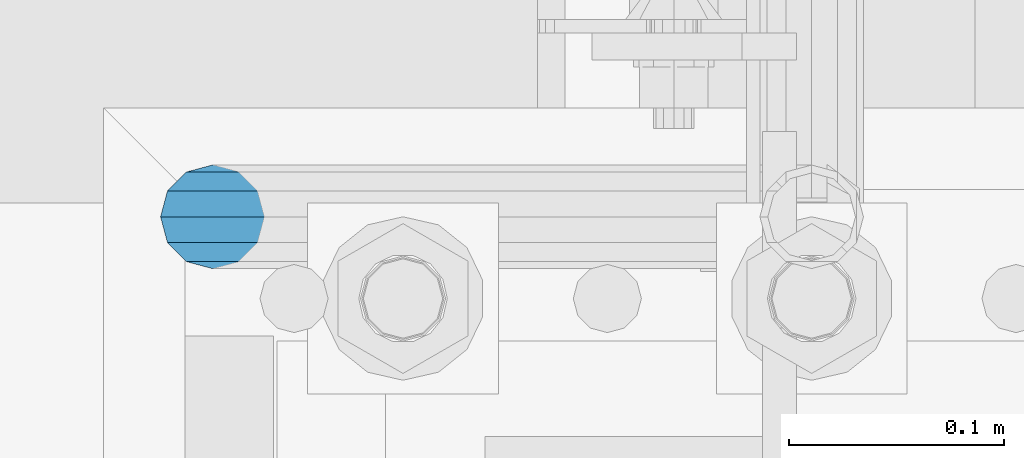
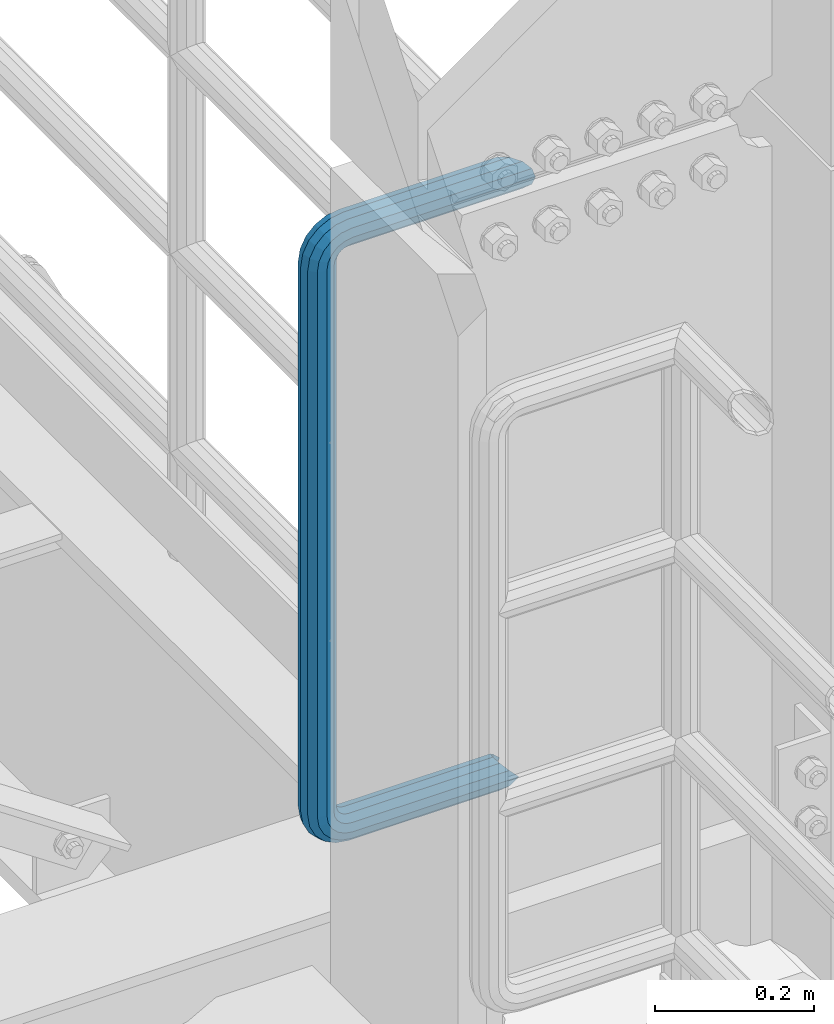
# One storey, part 989 of 1876: 1 beam, 1 element without a shape of its own.
"""IFC2X3 building model written with IfcOpenShell, lengths in millimetres."""

from ifc_helpers import new_model, si_unit, frame, origin_with_axes, place, context, subcontext, project, spatial, faceted_brep, material, type_object, element, aggregate, save


model = new_model("IFC2X3")

# Units and contexts
model_context = context("Model", 3, precision=1e-05, world=origin_with_axes())
body_context = subcontext(model_context, "Body", "Model", "MODEL_VIEW")
ifc_project = project(units=[si_unit("LENGTHUNIT", "METRE", prefix="MILLI"), si_unit("AREAUNIT", "SQUARE_METRE"), si_unit("VOLUMEUNIT", "CUBIC_METRE"), si_unit("MASSUNIT", "GRAM", prefix="KILO"), si_unit("TIMEUNIT", "SECOND"), si_unit("PLANEANGLEUNIT", "RADIAN"), si_unit("SOLIDANGLEUNIT", "STERADIAN"), si_unit("THERMODYNAMICTEMPERATUREUNIT", "DEGREE_CELSIUS"), si_unit("LUMINOUSINTENSITYUNIT", "LUMEN")], contexts=[model_context])

# Site, building, storey
site_placement = place(None, origin_with_axes())
site = spatial("IfcSite", under=ifc_project, at=site_placement, CompositionType="ELEMENT")
building_placement = place(site_placement, origin_with_axes())
building = spatial("IfcBuilding", under=site, at=building_placement, Name="Undefined", CompositionType="ELEMENT")
storey_placement = place(building_placement, origin_with_axes())
storey = spatial("IfcBuildingStorey", under=building, at=storey_placement, Name="Undefined", CompositionType="ELEMENT", Elevation=0.0)

# Assembly, beam
assembly_placement = place(storey_placement, origin_with_axes())
assembly = element("IfcElementAssembly", 1, at=assembly_placement, inside=storey, Name="RAIL", AssemblyPlace="NOTDEFINED", PredefinedType="RIGID_FRAME")
ifc_material = material()
beam_type = type_object("IfcBeamType", Name="PIPE1-1/2SCH40", PredefinedType="NOTDEFINED")
beam_placement = place(assembly_placement, frame((7620.00000000001, -4356.1, 14385.925), z_axis=(0.0, 0.0, 1.0), x_axis=(-1.0, 0.0, 0.0)))
beam = element("IfcBeam", 2, at=beam_placement, type_object=beam_type, material=ifc_material, Name="RAIL", ObjectType="PIPE1-1/2SCH40", context=body_context, shape_type="Brep", body=[
    faceted_brep([(1.20714750983051e-12, 24.1299999999974, -914.399963378906), (12.0650000000014, 20.8971929933159, -926.464963378905), (12.0650000000014, 20.8971929933177, -902.334963378908), (12.0650000000014, -20.8971929933195, -902.334963378908), (12.0650000000014, -20.8971929933195, -926.464963378905), (1.52133659548828e-12, -24.130000000001, -914.399963378906), (20.8971929933199, -12.0650000000023, -893.502770385589), (20.8971929933199, -12.0650000000005, -898.533841947723), (15.2545715621378, -17.7076214311819, -904.176463378906), (12.5151929933181, -20.4470000000019, -914.399963378906), (15.2545715621376, -17.7076214311819, -924.623463378906), (20.8971929933199, -12.0650000000005, -930.26608481009), (20.8971929933199, -12.0650000000023, -935.297156372224), (24.1300000000014, -1.81898940354586e-12, -934.846963378906), (24.1300000000014, -1.81898940354586e-12, -938.529963378907), (21.3906214311813, -10.2235000000019, -932.107584810088), (21.3906214311823, 10.2234999999982, -932.107584810088), (20.8971929933199, 12.0650000000005, -930.266084810086), (20.8971929933199, 12.0649999999987, -935.297156372224), (15.2545715621413, 17.7076214311783, -924.623463378906), (12.5151929933216, 20.4469999999983, -914.399963378906), (15.2545715621411, 17.7076214311783, -904.176463378906), (20.8971929933199, 12.0650000000005, -898.533841947727), (20.8971929933199, 12.0649999999987, -893.502770385589), (21.3906214311822, 10.2234999999982, -896.692341947724), (24.1300000000014, 0.0, -893.952963378906), (24.1300000000014, 0.0, -890.269963378905), (21.3906214311814, -10.2235000000019, -896.692341947724), (241.299995422363, -20.8971929933177, 12.0649999999987), (241.299995422363, -24.1299999999992, 0.0), (253.073542436527, -24.1299999999992, -1.86474665447167), (256.801832473661, -20.8971929933177, 9.60975021462946), (241.299995422363, -12.0650000000005, 20.8971929933177), (259.531130206197, -12.0650000000005, 18.0096649141014), (241.299995422363, 0.0, 24.130000000001), (260.530122510796, 0.0, 21.084247083727), (241.299995422363, 12.0650000000005, 20.8971929933177), (259.531130206197, 12.0650000000005, 18.0096649141014), (241.299995422363, 20.8971929933177, 12.0649999999987), (256.801832473661, 20.8971929933177, 9.60975021462946), (241.299995422363, 24.1299999999992, 0.0), (253.073542436527, 24.1299999999992, -1.86474665447167), (241.299995422363, 20.8971929933177, -12.0649999999987), (249.345252399393, 20.8971929933177, -13.3392435235728), (241.299995422363, 12.0650000000005, -20.8971929933177), (246.615954666858, 12.0650000000005, -21.7391582230448), (241.299995422363, 0.0, -24.130000000001), (245.616962362259, 0.0, -24.8137403926739), (241.299995422363, -12.0650000000005, -20.8971929933177), (246.615954666858, -12.0650000000005, -21.7391582230448), (241.299995422363, -20.8971929933177, -12.0649999999987), (249.345252399393, -20.8971929933177, -13.3392435235728), (267.334993896485, 20.8971929933177, -38.0999984741211), (279.399993896485, 24.1299999999992, -38.0999984741211), (279.399993896484, 24.1299999999992, -876.299964904785), (267.334993896484, 20.8971929933177, -876.299964904785), (291.464993896486, 20.8971929933177, -38.0999984741211), (291.464993896484, 20.8971929933177, -876.299964904785), (300.297186889804, 12.0650000000005, -38.0999984741211), (300.297186889803, 12.0650000000005, -876.299964904785), (303.529993896486, 0.0, -38.0999984741211), (303.529993896484, 0.0, -876.299964904785), (300.297186889804, -12.0650000000005, -38.0999984741211), (300.297186889803, -12.0650000000005, -876.299964904785), (291.464993896486, -20.8971929933177, -38.0999984741211), (291.464993896484, -20.8971929933177, -876.299964904785), (279.399993896484, -24.1299999999992, -38.0999984741211), (279.399993896484, -24.1299999999992, -876.299964904785), (267.334993896485, -20.8971929933177, -38.0999984741211), (267.334993896484, -20.8971929933177, -876.299964904785), (258.502800903167, -12.0650000000005, -38.0999984741211), (258.502800903166, -12.0650000000005, -876.299964904785), (255.269993896485, 0.0, -38.0999984741211), (255.269993896484, 0.0, -876.299964904785), (258.502800903167, 12.0650000000005, -38.0999984741211), (258.502800903166, 12.0650000000005, -876.299964904785), (257.660835673438, 12.0650000000005, -881.615924149282), (254.586253503809, 0.0, -880.616931844681), (257.660835673438, -12.0650000000005, -881.615924149282), (266.06075037291, -20.8971929933177, -884.345221881817), (277.535247242011, -24.130000000001, -888.073511918952), (289.009744111112, -20.8971929933195, -891.801801956084), (297.409658810584, -12.0650000000005, -894.531099688622), (300.484240980214, 0.0, -895.53009199322), (297.409658810584, 12.0650000000005, -894.531099688622), (289.009744111112, 20.8971929933177, -891.801801956084), (277.535247242011, 24.1299999999992, -888.073511918952), (266.06075037291, 20.8971929933177, -884.345221881817), (241.299995422364, -1.81898940354586e-12, -938.529963378911), (241.299995422364, -12.0650000000005, -935.297156372228), (241.299995422364, -20.8971929933195, -926.464963378909), (241.299995422363, -24.130000000001, -914.399963378906), (241.299995422363, -20.8971929933195, -902.334963378908), (241.299995422363, -12.0650000000005, -893.502770385589), (241.299995422363, 0.0, -890.269963378909), (241.299995422364, 20.8971929933177, -926.464963378909), (241.299995422364, 12.0649999999987, -935.297156372228), (241.299995422364, 24.1299999999992, -914.39996337891), (241.299995422363, 20.8971929933177, -902.334963378908), (241.299995422363, 12.0649999999987, -893.502770385589), (260.530122510801, 0.0, -935.484210462637), (259.531130206202, 12.0649999999987, -932.409628293008), (259.531130206201, -12.0650000000005, -932.409628293008), (256.801832473666, -20.8971929933195, -924.009713593536), (253.07354243653, -24.130000000001, -912.535216724435), (249.345252399395, -20.8971929933195, -901.060719855333), (246.615954666859, -12.0650000000005, -892.660805155861), (245.61696236226, 0.0, -889.586222986232), (246.615954666859, 12.0649999999987, -892.660805155861), (249.345252399395, 20.8971929933177, -901.060719855333), (253.07354243653, 24.1299999999992, -912.535216724435), (256.801832473666, 20.8971929933177, -924.009713593536), (275.977674493594, 12.0649999999987, -924.029695422345), (270.786241706733, 20.8971929933177, -916.884301193139), (277.877870775644, 0.0, -926.645091230272), (275.977674493608, -12.0650000000005, -924.029695422334), (270.786241706733, -20.8971929933195, -916.884301193139), (263.694612637823, -24.130000000001, -907.123511156005), (256.602983568912, -20.8971929933195, -897.362721118872), (251.411550782037, -12.0650000000005, -890.21732688968), (249.511354500001, 0.0, -887.601931081743), (251.411550782037, 12.0650000000005, -890.21732688968), (256.602983568912, 20.8971929933177, -897.362721118872), (263.694612637823, 24.1299999999992, -907.123511156005), (281.884331710718, 20.8971929933177, -905.786211189152), (272.123541673585, 24.1299999999992, -898.694582120243), (289.029725939912, 12.0650000000005, -910.977643976028), (291.645121747852, 0.0, -912.877840258065), (289.029725939912, -12.0650000000005, -910.977643976028), (281.884331710718, -20.8971929933195, -905.786211189152), (272.123541673585, -24.130000000001, -898.694582120243), (262.362751636451, -20.8971929933195, -891.602953051333), (255.217357407258, -12.0650000000005, -886.411520264461), (252.601961599318, 0.0, -884.511323982424), (255.217357407258, 12.0650000000005, -886.411520264461), (262.362751636451, 20.8971929933177, -891.602953051333), (266.060750372911, 20.8971929933177, -30.0547414970897), (257.660835673439, 12.0650000000005, -32.7840392296275), (277.535247242011, 24.1299999999992, -26.3264514599541), (289.009744111112, 20.8971929933177, -22.5981614228222), (297.409658810584, 12.0650000000005, -19.8688636902843), (300.484240980213, 0.0, -18.8698713856866), (297.409658810584, -12.0650000000005, -19.8688636902843), (289.009744111112, -20.8971929933177, -22.5981614228222), (277.535247242011, -24.1299999999992, -26.3264514599541), (266.060750372911, -20.8971929933177, -30.0547414970897), (257.660835673439, -12.0650000000005, -32.7840392296275), (254.58625350381, 0.0, -33.7830315342253), (255.217357407257, 12.0650000000005, -27.9884431144455), (252.601961599318, 0.0, -29.8886393964822), (262.362751636451, 20.8971929933177, -22.7970103275729), (272.123541673583, 24.1299999999992, -15.7053812586601), (281.884331710716, 20.8971929933177, -8.61375218975081), (289.029725939909, 12.0650000000005, -3.42231940287456), (291.645121747848, 0.0, -1.52212312084157), (289.029725939909, -12.0650000000005, -3.42231940287456), (281.884331710716, -20.8971929933177, -8.61375218975081), (272.123541673583, -24.1299999999992, -15.7053812586601), (262.362751636451, -20.8971929933177, -22.7970103275729), (255.217357407257, -12.0650000000005, -27.9884431144455), (249.511354500002, 0.0, -26.7980322971671), (251.411550782037, -12.0650000000005, -24.1826364892258), (251.411550782037, 12.0650000000005, -24.1826364892258), (256.602983568912, 20.8971929933177, -17.037242260034), (263.694612637822, 24.1299999999992, -7.27645222290084), (270.786241706732, 20.8971929933177, 2.48433781423228), (275.977674493607, 12.0650000000005, 9.62973204342416), (277.877870775642, 0.0, 12.2451278513654), (275.977674493607, -12.0650000000005, 9.62973204342416), (270.786241706732, -20.8971929933177, 2.48433781423228), (263.694612637822, -24.1299999999992, -7.27645222290084), (256.602983568912, -20.8971929933177, -17.037242260034), (24.1299999999854, -24.1299999999992, 0.0), (20.8971929933039, -20.8971929933177, -12.0649999999987), (12.0649999999854, -12.0650000000005, -20.8971929933177), (20.8971929933249, -12.0650000000005, -20.8971929933177), (16.4810997545745, -16.4810997545883, -16.48109323873), (24.1300000000063, 0.0, -24.130000000001), (-1.45519152283669e-11, 0.0, -24.130000000001), (20.8971929933249, 12.0650000000005, -20.8971929933177), (-12.0650000000145, 12.0650000000005, -20.8971929933177), (-20.897192993333, 20.8971929933177, -12.0649999999987), (-12.0649999999986, 20.8971929933177, -12.0649999999987), (12.0650000000064, 20.8971929933177, -12.0649999999987), (-16.481093238746, 16.4810932387318, -16.4810997545865), (0.0, 24.1299999999992, 0.0), (-24.1300000000145, 24.1299999999992, 0.0), (-20.897192993333, 20.8971929933177, 12.0649999999987), (-12.0650000000145, 12.0650000000005, 20.8971929933177), (-1.45519152283669e-11, 0.0, 24.130000000001), (12.0649999999854, -12.0650000000005, 20.8971929933177), (20.8971929933039, -20.8971929933177, 12.0649999999987), (241.299995422363, -17.7076214311801, 10.2235000000001), (241.299995422363, -20.4470000000001, 0.0), (20.4469999999854, -20.4470000000001, 0.0), (17.7076214311658, -17.7076214311801, 10.2235000000001), (241.299995422363, 0.0, 20.4470000000001), (241.299995422363, -10.2235000000001, 17.7076214311819), (10.2234999999854, -10.2235000000001, 17.7076214311819), (-1.45519152283669e-11, 0.0, 20.4470000000001), (241.299995422363, 10.2235000000001, 17.7076214311819), (-10.2235000000145, 10.2235000000001, 17.7076214311819), (241.299995422363, 17.7076214311801, 10.2235000000001), (-17.7076214311949, 17.7076214311801, 10.2235000000001), (241.299995422363, 20.4470000000001, 0.0), (-20.4470000000145, 20.4470000000001, 0.0), (241.299995422363, 17.7076214311801, -10.2235000000001), (-17.7076214311949, 17.7076214311801, -10.2235000000001), (241.299995422363, 10.2235000000001, -17.7076214311819), (-10.2235000000145, 10.2235000000001, -17.7076214311819), (241.299995422363, 0.0, -20.4470000000001), (-1.45519152283669e-11, 0.0, -20.4470000000001), (241.299995422363, -10.2235000000001, -17.7076214311819), (10.2234999999854, -10.2235000000001, -17.7076214311819), (241.299995422363, -17.7076214311801, -10.2235000000001), (17.7076214311658, -17.7076214311801, -10.2235000000001), (258.545498388721, -10.2235000000001, 14.9762020957387), (256.23277767852, -17.7076214311801, 7.85837963987069), (253.073542436527, -20.4470000000001, -1.86474665447167), (249.914307194535, -17.7076214311801, -11.5878729488177), (247.601586484334, -10.2235000000001, -18.7056954046857), (246.755071952542, 0.0, -21.31099924316), (247.601586484334, 10.2235000000001, -18.7056954046857), (249.914307194535, 17.7076214311801, -11.5878729488177), (253.073542436527, 20.4470000000001, -1.86474665447167), (256.23277767852, 17.7076214311801, 7.85837963987069), (258.545498388721, 10.2235000000001, 14.9762020957387), (259.392012920513, 0.0, 17.5815059342131), (275.713057691449, 0.0, 9.26551826108334), (274.10289136825, -10.2235000000001, 7.04931444488102), (274.10289136825, 10.2235000000001, 7.04931444488102), (269.703835164635, 17.7076214311801, 0.994533019089431), (263.694612637822, 20.4470000000001, -7.27645222290084), (257.685390111009, 17.7076214311801, -15.5474374648911), (253.286333907394, 10.2235000000001, -21.6022188906827), (251.676167584195, 0.0, -23.818422706885), (253.286333907394, -10.2235000000001, -21.6022188906827), (257.685390111009, -17.7076214311801, -15.5474374648911), (263.694612637822, -20.4470000000001, -7.27645222290084), (269.703835164635, -17.7076214311801, 0.994533019089431), (286.449308341364, -10.2235000000001, -5.29710252823133), (280.394526915574, -17.7076214311801, -9.69615873184739), (288.665512157566, 0.0, -3.68693620503473), (286.449308341364, 10.2235000000001, -5.29710252823133), (280.394526915574, 17.7076214311801, -9.69615873184739), (272.123541673583, 20.4470000000001, -15.7053812586601), (263.852556431592, 17.7076214311801, -21.7146037854764), (257.797775005802, 10.2235000000001, -26.1136599890888), (255.581571189601, 0.0, -27.723826312289), (257.797775005802, -10.2235000000001, -26.1136599890888), (263.852556431592, -17.7076214311801, -21.7146037854764), (272.123541673583, -20.4470000000001, -15.7053812586601), (287.258373536355, -17.7076214311801, -23.1672162179639), (277.535247242011, -20.4470000000001, -26.3264514599541), (294.376195992223, -10.2235000000001, -20.8544955077632), (296.981499830698, 0.0, -20.00798097597), (294.376195992223, 10.2235000000001, -20.8544955077632), (287.258373536355, 17.7076214311801, -23.1672162179639), (277.535247242011, 20.4470000000001, -26.3264514599541), (267.812120947668, 17.7076214311801, -29.485686701948), (260.6942984918, 10.2235000000001, -31.7984074121487), (258.088994653325, 0.0, -32.6449219439419), (260.6942984918, -10.2235000000001, -31.7984074121487), (267.812120947668, -17.7076214311801, -29.485686701948), (279.399993896484, -20.4470000000001, -38.0999984741211), (269.176493896485, -17.7076214311801, -38.0999984741211), (289.623493896486, -17.7076214311801, -38.0999984741211), (297.107615327666, -10.2235000000001, -38.0999984741211), (299.846993896486, 0.0, -38.0999984741211), (297.107615327666, 10.2235000000001, -38.0999984741211), (289.623493896486, 17.7076214311801, -38.0999984741211), (279.399993896485, 20.4470000000001, -38.0999984741211), (269.176493896485, 17.7076214311801, -38.0999984741211), (261.692372465305, 10.2235000000001, -38.0999984741211), (258.952993896485, 0.0, -38.0999984741211), (261.692372465305, -10.2235000000001, -38.0999984741211), (269.176493896484, -17.7076214311801, -876.299964904785), (261.692372465304, -10.2235000000001, -876.299964904785), (258.952993896484, 0.0, -876.299964904785), (261.692372465304, 10.2235000000001, -876.299964904785), (269.176493896484, 17.7076214311801, -876.299964904785), (279.399993896484, 20.4470000000001, -876.299964904785), (289.623493896484, 17.7076214311801, -876.299964904785), (297.107615327665, 10.2235000000001, -876.299964904785), (299.846993896484, 0.0, -876.299964904785), (297.107615327665, -10.2235000000001, -876.299964904785), (289.623493896484, -17.7076214311801, -876.299964904785), (279.399993896484, -20.4470000000001, -876.299964904785), (277.535247242011, -20.4470000000001, -888.073511918952), (267.812120947667, -17.7076214311801, -884.914276676958), (260.694298491799, -10.2235000000001, -882.601555966758), (258.088994653324, 0.0, -881.755041434964), (260.694298491799, 10.2235000000001, -882.601555966758), (267.812120947668, 17.7076214311801, -884.914276676958), (277.535247242011, 20.4470000000001, -888.073511918952), (287.258373536355, 17.7076214311801, -891.232747160942), (294.376195992223, 10.2235000000001, -893.545467871143), (296.981499830699, 0.0, -894.391982402936), (294.376195992223, -10.2235000000001, -893.545467871143), (287.258373536355, -17.7076214311801, -891.232747160942), (280.394526915577, -17.7076214311801, -904.703804647055), (272.123541673585, -20.4470000000001, -898.694582120243), (286.449308341367, -10.2235000000001, -909.102860850671), (288.665512157569, 0.0, -910.713027173868), (286.449308341367, 10.2235000000001, -909.102860850671), (280.394526915577, 17.7076214311801, -904.703804647055), (272.123541673585, 20.4470000000001, -898.694582120243), (263.852556431593, 17.7076214311801, -892.68535959343), (257.797775005802, 10.2235000000001, -888.286303389817), (255.581571189601, 0.0, -886.676137066617), (257.797775005802, -10.2235000000001, -888.286303389817), (263.852556431593, -17.7076214311801, -892.68535959343), (263.694612637823, -20.4470000000001, -907.123511156005), (257.685390111009, -17.7076214311801, -898.852525914015), (269.703835164636, -17.7076214311801, -915.394496397999), (274.102891368238, -10.2235000000001, -921.449277823798), (275.71305769145, 0.0, -923.66548163999), (274.102891368251, 10.2235000000001, -921.449277823787), (269.703835164636, 17.7076214311801, -915.394496397999), (263.694612637823, 20.4470000000001, -907.123511156005), (257.685390111009, 17.7076214311801, -898.852525914015), (253.286333907394, 10.2235000000001, -892.797744488227), (251.676167584195, 0.0, -890.581540672025), (253.286333907394, -10.2235000000001, -892.797744488227), (249.914307194537, -17.7076214311801, -902.812090430092), (247.601586484335, -10.2235000000001, -895.694267974224), (253.07354243653, -20.4470000000001, -912.535216724435), (256.232777678524, -17.7076214311819, -922.258343018777), (258.545498388725, -10.2235000000001, -929.376165474645), (259.392012920517, 0.0, -931.981469313119), (258.545498388725, 10.2235000000001, -929.376165474645), (256.232777678524, 17.7076214311801, -922.258343018777), (253.07354243653, 20.4470000000001, -912.535216724435), (249.914307194537, 17.7076214311801, -902.812090430092), (247.601586484335, 10.2235000000001, -895.694267974224), (246.755071952543, 0.0, -893.088964135746), (241.299995422363, -10.2235000000001, -896.692341947728), (241.299995422363, 0.0, -893.95296337891), (241.299995422363, -17.7076214311819, -904.17646337891), (241.299995422363, -20.4470000000001, -914.399963378906), (241.299995422364, -17.7076214311819, -924.62346337891), (241.299995422364, -10.2235000000001, -932.107584810088), (241.299995422364, -1.81898940354586e-12, -934.84696337891), (241.299995422364, 10.2234999999982, -932.107584810088), (241.299995422364, 17.7076214311801, -924.62346337891), (241.299995422364, 20.4470000000001, -914.39996337891), (241.299995422363, 17.7076214311801, -904.17646337891), (241.299995422363, 10.2235000000001, -896.692341947728)], [[[0, 1, 2]], [[3, 4, 5]], [[6, 7, 8, 9, 10, 11, 12, 4, 3]], [[13, 14, 12, 11, 15]], [[16, 17, 18, 14, 13]], [[2, 1, 18, 17, 19, 20, 21, 22, 23]], [[23, 22, 24, 25, 26]], [[26, 25, 27, 7, 6]], [[28, 29, 30, 31]], [[32, 28, 31, 33]], [[34, 32, 33, 35]], [[36, 34, 35, 37]], [[38, 36, 37, 39]], [[40, 38, 39, 41]], [[42, 40, 41, 43]], [[44, 42, 43, 45]], [[46, 44, 45, 47]], [[48, 46, 47, 49]], [[50, 48, 49, 51]], [[52, 53, 54, 55]], [[53, 56, 57, 54]], [[56, 58, 59, 57]], [[58, 60, 61, 59]], [[60, 62, 63, 61]], [[62, 64, 65, 63]], [[64, 66, 67, 65]], [[66, 68, 69, 67]], [[68, 70, 71, 69]], [[70, 72, 73, 71]], [[72, 74, 75, 73]], [[73, 75, 76, 77]], [[71, 73, 77, 78]], [[69, 71, 78, 79]], [[67, 69, 79, 80]], [[65, 67, 80, 81]], [[63, 65, 81, 82]], [[61, 63, 82, 83]], [[59, 61, 83, 84]], [[57, 59, 84, 85]], [[54, 57, 85, 86]], [[55, 54, 86, 87]], [[88, 89, 12, 14]], [[89, 90, 4, 12]], [[90, 91, 5, 4]], [[91, 92, 3, 5]], [[92, 93, 6, 3]], [[93, 94, 26, 6]], [[95, 96, 18, 1]], [[97, 95, 1, 0]], [[98, 97, 0, 2]], [[99, 98, 2, 23]], [[94, 99, 23, 26]], [[96, 88, 14, 18]], [[100, 88, 96, 101]], [[102, 89, 88, 100]], [[103, 90, 89, 102]], [[104, 91, 90, 103]], [[105, 92, 91, 104]], [[106, 93, 92, 105]], [[107, 94, 93, 106]], [[108, 99, 94, 107]], [[109, 98, 99, 108]], [[110, 97, 98, 109]], [[111, 95, 97, 110]], [[101, 96, 95, 111]], [[112, 101, 111, 113]], [[114, 100, 101, 112]], [[115, 102, 100, 114]], [[116, 103, 102, 115]], [[117, 104, 103, 116]], [[118, 105, 104, 117]], [[119, 106, 105, 118]], [[120, 107, 106, 119]], [[121, 108, 107, 120]], [[122, 109, 108, 121]], [[123, 110, 109, 122]], [[113, 111, 110, 123]], [[124, 113, 123, 125]], [[126, 112, 113, 124]], [[127, 114, 112, 126]], [[128, 115, 114, 127]], [[129, 116, 115, 128]], [[130, 117, 116, 129]], [[131, 118, 117, 130]], [[132, 119, 118, 131]], [[133, 120, 119, 132]], [[134, 121, 120, 133]], [[135, 122, 121, 134]], [[125, 123, 122, 135]], [[86, 125, 135, 87]], [[85, 124, 125, 86]], [[84, 126, 124, 85]], [[83, 127, 126, 84]], [[82, 128, 127, 83]], [[81, 129, 128, 82]], [[80, 130, 129, 81]], [[79, 131, 130, 80]], [[78, 132, 131, 79]], [[77, 133, 132, 78]], [[76, 134, 133, 77]], [[87, 135, 134, 76]], [[75, 55, 87, 76]], [[74, 52, 55, 75]], [[136, 52, 74, 137]], [[138, 53, 52, 136]], [[139, 56, 53, 138]], [[140, 58, 56, 139]], [[141, 60, 58, 140]], [[142, 62, 60, 141]], [[143, 64, 62, 142]], [[144, 66, 64, 143]], [[145, 68, 66, 144]], [[146, 70, 68, 145]], [[147, 72, 70, 146]], [[137, 74, 72, 147]], [[148, 137, 147, 149]], [[150, 136, 137, 148]], [[151, 138, 136, 150]], [[152, 139, 138, 151]], [[153, 140, 139, 152]], [[154, 141, 140, 153]], [[155, 142, 141, 154]], [[156, 143, 142, 155]], [[157, 144, 143, 156]], [[158, 145, 144, 157]], [[159, 146, 145, 158]], [[149, 147, 146, 159]], [[160, 149, 159, 161]], [[162, 148, 149, 160]], [[163, 150, 148, 162]], [[164, 151, 150, 163]], [[165, 152, 151, 164]], [[166, 153, 152, 165]], [[167, 154, 153, 166]], [[168, 155, 154, 167]], [[169, 156, 155, 168]], [[170, 157, 156, 169]], [[171, 158, 157, 170]], [[161, 159, 158, 171]], [[49, 161, 171, 51]], [[47, 160, 161, 49]], [[45, 162, 160, 47]], [[43, 163, 162, 45]], [[41, 164, 163, 43]], [[39, 165, 164, 41]], [[37, 166, 165, 39]], [[35, 167, 166, 37]], [[33, 168, 167, 35]], [[31, 169, 168, 33]], [[30, 170, 169, 31]], [[51, 171, 170, 30]], [[29, 50, 51, 30]], [[50, 29, 172, 173]], [[174, 175, 48, 50, 173, 176]], [[177, 46, 48, 175, 174, 178]], [[179, 44, 46, 177, 178, 180]], [[181, 182, 183, 42, 44, 179, 180, 184]], [[185, 40, 42, 183, 182, 181, 186]], [[38, 40, 185, 186, 187]], [[36, 38, 187, 188]], [[34, 36, 188, 189]], [[32, 34, 189, 190]], [[28, 32, 190, 191]], [[29, 28, 191, 172]], [[192, 193, 194, 195]], [[196, 197, 198, 199]], [[200, 196, 199, 201]], [[202, 200, 201, 203]], [[204, 202, 203, 205]], [[206, 204, 205, 207]], [[208, 206, 207, 209]], [[210, 208, 209, 211]], [[212, 210, 211, 213]], [[214, 212, 213, 215]], [[193, 214, 215, 194]], [[190, 189, 188, 187, 186, 181, 184, 180, 178, 174, 176, 173, 172, 191], [213, 211, 209, 207, 205, 203, 201, 199, 198, 195, 194, 215]], [[197, 192, 195, 198]], [[192, 197, 216, 217]], [[193, 192, 217, 218]], [[214, 193, 218, 219]], [[212, 214, 219, 220]], [[210, 212, 220, 221]], [[208, 210, 221, 222]], [[206, 208, 222, 223]], [[204, 206, 223, 224]], [[202, 204, 224, 225]], [[200, 202, 225, 226]], [[196, 200, 226, 227]], [[197, 196, 227, 216]], [[227, 228, 229, 216]], [[226, 230, 228, 227]], [[225, 231, 230, 226]], [[224, 232, 231, 225]], [[223, 233, 232, 224]], [[222, 234, 233, 223]], [[221, 235, 234, 222]], [[220, 236, 235, 221]], [[219, 237, 236, 220]], [[218, 238, 237, 219]], [[217, 239, 238, 218]], [[216, 229, 239, 217]], [[229, 240, 241, 239]], [[228, 242, 240, 229]], [[230, 243, 242, 228]], [[231, 244, 243, 230]], [[232, 245, 244, 231]], [[233, 246, 245, 232]], [[234, 247, 246, 233]], [[235, 248, 247, 234]], [[236, 249, 248, 235]], [[237, 250, 249, 236]], [[238, 251, 250, 237]], [[239, 241, 251, 238]], [[241, 252, 253, 251]], [[240, 254, 252, 241]], [[242, 255, 254, 240]], [[243, 256, 255, 242]], [[244, 257, 256, 243]], [[245, 258, 257, 244]], [[246, 259, 258, 245]], [[247, 260, 259, 246]], [[248, 261, 260, 247]], [[249, 262, 261, 248]], [[250, 263, 262, 249]], [[251, 253, 263, 250]], [[253, 264, 265, 263]], [[252, 266, 264, 253]], [[254, 267, 266, 252]], [[255, 268, 267, 254]], [[256, 269, 268, 255]], [[257, 270, 269, 256]], [[258, 271, 270, 257]], [[259, 272, 271, 258]], [[260, 273, 272, 259]], [[261, 274, 273, 260]], [[262, 275, 274, 261]], [[263, 265, 275, 262]], [[275, 265, 276, 277]], [[274, 275, 277, 278]], [[273, 274, 278, 279]], [[272, 273, 279, 280]], [[271, 272, 280, 281]], [[270, 271, 281, 282]], [[269, 270, 282, 283]], [[268, 269, 283, 284]], [[267, 268, 284, 285]], [[266, 267, 285, 286]], [[264, 266, 286, 287]], [[265, 264, 287, 276]], [[276, 287, 288, 289]], [[277, 276, 289, 290]], [[278, 277, 290, 291]], [[279, 278, 291, 292]], [[280, 279, 292, 293]], [[281, 280, 293, 294]], [[282, 281, 294, 295]], [[283, 282, 295, 296]], [[284, 283, 296, 297]], [[285, 284, 297, 298]], [[286, 285, 298, 299]], [[287, 286, 299, 288]], [[299, 300, 301, 288]], [[298, 302, 300, 299]], [[297, 303, 302, 298]], [[296, 304, 303, 297]], [[295, 305, 304, 296]], [[294, 306, 305, 295]], [[293, 307, 306, 294]], [[292, 308, 307, 293]], [[291, 309, 308, 292]], [[290, 310, 309, 291]], [[289, 311, 310, 290]], [[288, 301, 311, 289]], [[301, 312, 313, 311]], [[300, 314, 312, 301]], [[302, 315, 314, 300]], [[303, 316, 315, 302]], [[304, 317, 316, 303]], [[305, 318, 317, 304]], [[306, 319, 318, 305]], [[307, 320, 319, 306]], [[308, 321, 320, 307]], [[309, 322, 321, 308]], [[310, 323, 322, 309]], [[311, 313, 323, 310]], [[313, 324, 325, 323]], [[312, 326, 324, 313]], [[314, 327, 326, 312]], [[315, 328, 327, 314]], [[316, 329, 328, 315]], [[317, 330, 329, 316]], [[318, 331, 330, 317]], [[319, 332, 331, 318]], [[320, 333, 332, 319]], [[321, 334, 333, 320]], [[322, 335, 334, 321]], [[323, 325, 335, 322]], [[325, 336, 337, 335]], [[324, 338, 336, 325]], [[326, 339, 338, 324]], [[327, 340, 339, 326]], [[328, 341, 340, 327]], [[329, 342, 341, 328]], [[330, 343, 342, 329]], [[331, 344, 343, 330]], [[332, 345, 344, 331]], [[333, 346, 345, 332]], [[334, 347, 346, 333]], [[335, 337, 347, 334]], [[347, 337, 25, 24]], [[21, 346, 347, 24, 22]], [[345, 346, 21, 20]], [[344, 345, 20, 19]], [[343, 344, 19, 17, 16]], [[342, 343, 16, 13]], [[341, 342, 13, 15]], [[10, 340, 341, 15, 11]], [[339, 340, 10, 9]], [[338, 339, 9, 8]], [[336, 338, 8, 7, 27]], [[337, 336, 27, 25]]]),
])
aggregate(assembly, [beam])

save(model, "model.ifc")
